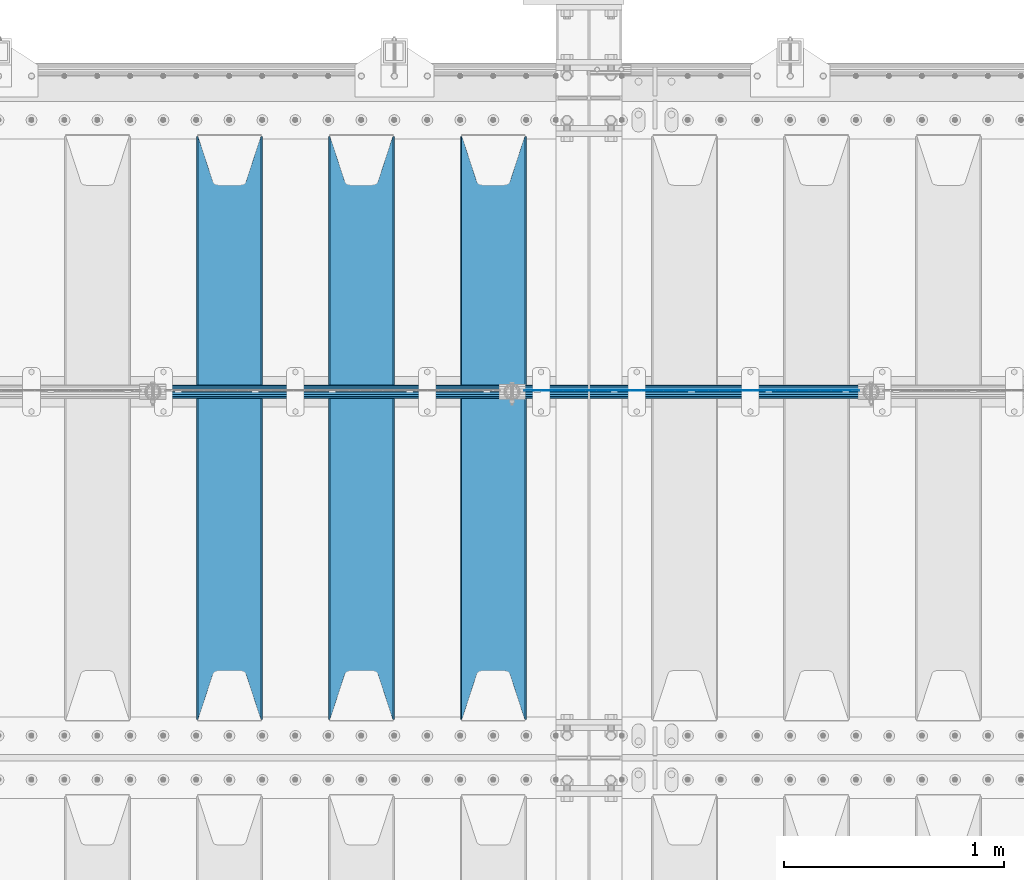
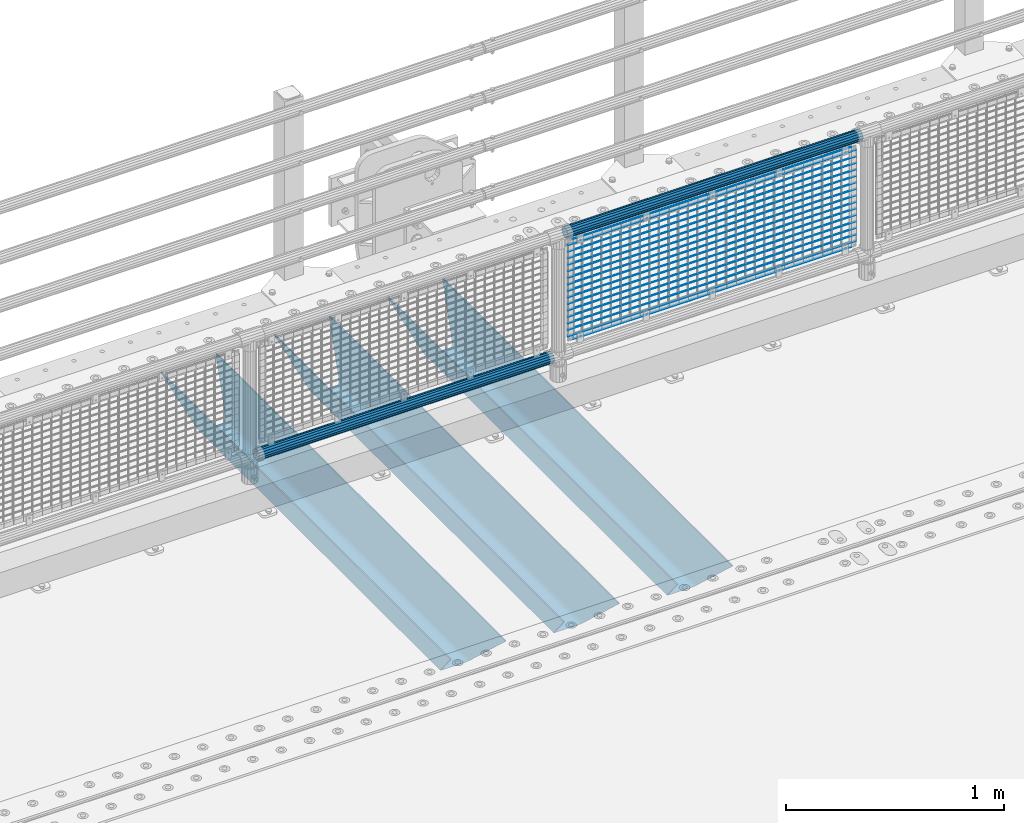
# One storey, part 126 of 242: 22 beams.
"""IFC2X3 building model written with IfcOpenShell, lengths in millimetres."""

import ifcopenshell
import ifcopenshell.guid

model = None  # the IFC model being written
_history = None  # IfcOwnerHistory: only IFC2X3 demands one
_inside = {}  # id of a spatial element -> (the spatial element, [elements in it])
_under = {}  # id of a project, library or spatial element -> (it, [spatial elements below it])
_declared = {}  # id of a project -> (the project, [libraries it declares])
_typed = {}  # id of a type object -> (the type object, [elements of that type])
_made_of = {}  # id of a material, layer set ... -> (it, [elements and type objects made of it])


def new_model(schema):
    """Start an empty IFC model of exactly this schema.

    Asked for "IFC4X3", IfcOpenShell would pick the latest addendum, in which some entities
    have other attributes; the version numbers below select the first issue.
    IFC2X3 requires an IfcOwnerHistory on every rooted entity: one is made here for all.
    """
    global model, _history
    if schema == "IFC4X3":
        model = ifcopenshell.file(schema_version=(4, 3, 0, 0))
    else:
        model = ifcopenshell.file(schema=schema)
    _inside.clear()
    _under.clear()
    _declared.clear()
    _typed.clear()
    _made_of.clear()
    _history = None
    if model.schema == "IFC2X3":
        org = make("IfcOrganization", Name="unknown")
        user = make(
            "IfcPersonAndOrganization",
            ThePerson=make("IfcPerson", FamilyName="unknown"),
            TheOrganization=org,
        )
        app = make(
            "IfcApplication",
            ApplicationDeveloper=org,
            Version="unknown",
            ApplicationFullName="unknown",
            ApplicationIdentifier="unknown",
        )
        _history = make(
            "IfcOwnerHistory",
            OwningUser=user,
            OwningApplication=app,
            ChangeAction="ADDED",
            CreationDate=0,
        )
    return model


def make(cls, **values):
    """One entity of the class cls with the attributes given. An attribute that is None is left unset."""
    return model.create_entity(
        cls, **{name: value for name, value in values.items() if value is not None}
    )


def rooted(cls, **values):
    """An entity with a GlobalId (a new one), such as an element, a storey or a relation."""
    return make(cls, GlobalId=ifcopenshell.guid.new(), OwnerHistory=_history, **values)


def si_unit(unit_type, name, prefix=None):
    """IfcSIUnit, for example si_unit("LENGTHUNIT", "METRE", prefix="MILLI")."""
    return make("IfcSIUnit", UnitType=unit_type, Prefix=prefix, Name=name)


def assignment(units):
    """IfcUnitAssignment: the units of a project."""
    return None if units is None else make("IfcUnitAssignment", Units=units)


def point(xyz):
    """IfcCartesianPoint."""
    return None if xyz is None else make("IfcCartesianPoint", Coordinates=xyz)


def direction(xyz):
    """IfcDirection."""
    return None if xyz is None else make("IfcDirection", DirectionRatios=xyz)


def frame(location, z_axis=None, x_axis=None):
    """IfcAxis2Placement3D, a coordinate frame: its origin and axes. An axis left out is left unset."""
    return make(
        "IfcAxis2Placement3D",
        Location=point(location),
        Axis=direction(z_axis),
        RefDirection=direction(x_axis),
    )


def origin_with_axes():
    """The frame at (0, 0, 0) with the z axis (0, 0, 1) and the x axis (1, 0, 0) written out."""
    return frame((0.0, 0.0, 0.0), z_axis=(0.0, 0.0, 1.0), x_axis=(1.0, 0.0, 0.0))


def place(relative_to, where):
    """IfcLocalPlacement: puts the frame where relative to a parent placement (None: the world)."""
    return make(
        "IfcLocalPlacement", PlacementRelTo=relative_to, RelativePlacement=where
    )


def context(
    kind, dimensions, precision=None, world=None, true_north=None, identifier=None
):
    """IfcGeometricRepresentationContext, for example the 3D "Model" context."""
    return make(
        "IfcGeometricRepresentationContext",
        ContextIdentifier=identifier,
        ContextType=kind,
        CoordinateSpaceDimension=dimensions,
        Precision=precision,
        WorldCoordinateSystem=world,
        TrueNorth=true_north,
    )


def subcontext(parent, identifier, kind, view, scale=None):
    """IfcGeometricRepresentationSubContext, for example "Body" below "Model"."""
    return make(
        "IfcGeometricRepresentationSubContext",
        ContextIdentifier=identifier,
        ContextType=kind,
        ParentContext=parent,
        TargetScale=scale,
        TargetView=view,
    )


def project(units=None, contexts=None):
    """IfcProject with its units and contexts."""
    return rooted(
        "IfcProject",
        Name="project",
        RepresentationContexts=contexts,
        UnitsInContext=assignment(units),
    )


def spatial(cls, under=None, at=None, **own):
    """A site, building, storey or space (cls), placed at a placement, below another one or the project."""
    s = rooted(cls, ObjectPlacement=at, **own)
    if under is not None:
        _under.setdefault(under.id(), (under, []))[1].append(s)
    return s


def faces_of(points, faces, orient=None, outer=None):
    """IfcFace entities. A face is a list of loops; a loop is a list of indices into points, from 0.

    orient and outer hold one flag for each loop. By default every Orientation is true, the
    first loop of a face is its IfcFaceOuterBound and the others are IfcFaceBound.
    """
    made = []
    for i, loops in enumerate(faces):
        bounds = []
        for j, loop in enumerate(loops):
            is_outer = j == 0 if outer is None else outer[i][j]
            bounds.append(
                make(
                    "IfcFaceOuterBound" if is_outer else "IfcFaceBound",
                    Bound=make("IfcPolyLoop", Polygon=[points[k] for k in loop]),
                    Orientation=True if orient is None else orient[i][j],
                )
            )
        made.append(make("IfcFace", Bounds=bounds))
    return made


def faceted_brep(points, faces, orient=None, outer=None, voids=None):
    """IfcFacetedBrep: a solid bounded by flat faces; with voids (closed shells), ...WithVoids."""
    shared = [point(p) for p in points]
    hull = make("IfcClosedShell", CfsFaces=faces_of(shared, faces, orient, outer))
    if voids is None:
        return make("IfcFacetedBrep", Outer=hull)
    return make(
        "IfcFacetedBrepWithVoids",
        Outer=hull,
        Voids=[
            make(cls, CfsFaces=faces_of(shared, fs, o, b)) for cls, fs, o, b in voids
        ],
    )


def shape(context_of_items, identifier, shape_type, items):
    """IfcShapeRepresentation: the items that make up one representation, for example the "Body"."""
    return make(
        "IfcShapeRepresentation",
        ContextOfItems=context_of_items,
        RepresentationIdentifier=identifier,
        RepresentationType=shape_type,
        Items=items,
    )


def material(Name=None, Category=None):
    """IfcMaterial."""
    return make("IfcMaterial", Name=Name, Category=Category)


def made_of(thing, what):
    """Note that an element or type object is made of a material, layer set ...; save() writes the relation."""
    if what is not None:
        _made_of.setdefault(what.id(), (what, []))[1].append(thing)
    return thing


def type_object(cls, material=None, **own):
    """A type object (cls), such as IfcWallType, which elements share."""
    return made_of(rooted(cls, **own), material)


def element(
    cls,
    number,
    at=None,
    inside=None,
    cuts=None,
    type_object=None,
    material=None,
    context=None,
    identifier="Body",
    shape_type=None,
    held_by="IfcProductDefinitionShape",
    body=None,
    shapes=None,
    **own,
):
    """One element of the class cls, such as IfcWall. Its Tag is "e" and its number.

    at: its placement. inside: the storey or other place that contains it. cuts: it is an
    opening in that element (IfcRelVoidsElement). A single representation is given by context,
    identifier, shape_type and body (its items); several are given by shapes. held_by: the class
    of the entity that holds the representations. save() writes the other relations.
    """
    e = rooted(cls, Tag="e%d" % number, ObjectPlacement=at, **own)
    if body is not None:
        shapes = [shape(context, identifier, shape_type, body)]
    if shapes is not None:
        e.Representation = make(held_by, Representations=shapes)
    if inside is not None:
        _inside.setdefault(inside.id(), (inside, []))[1].append(e)
    if cuts is not None:
        rooted(
            "IfcRelVoidsElement", RelatingBuildingElement=cuts, RelatedOpeningElement=e
        )
    if type_object is not None:
        _typed.setdefault(type_object.id(), (type_object, []))[1].append(e)
    return made_of(e, material)


def aggregate(whole, parts):
    """IfcRelAggregates: a whole, such as a stair, and the parts it consists of."""
    return rooted("IfcRelAggregates", RelatingObject=whole, RelatedObjects=parts)


def save(model, path):
    """Write the relations noted so far, then the file.

    IfcRelAggregates (storeys below a building ...), IfcRelContainedInSpatialStructure (elements
    in a storey), IfcRelDefinesByType, IfcRelAssociatesMaterial and IfcRelDeclares: one each for
    every whole, place, type object, material and project.
    """
    for whole, parts in _under.values():
        aggregate(whole, parts)
    for where, things in _inside.values():
        rooted(
            "IfcRelContainedInSpatialStructure",
            RelatedElements=things,
            RelatingStructure=where,
        )
    for kind, things in _typed.values():
        rooted("IfcRelDefinesByType", RelatedObjects=things, RelatingType=kind)
    for what, things in _made_of.values():
        rooted("IfcRelAssociatesMaterial", RelatedObjects=things, RelatingMaterial=what)
    for by, libraries in _declared.values():
        rooted("IfcRelDeclares", RelatingContext=by, RelatedDefinitions=libraries)
    model.write(path)


model = new_model("IFC2X3")

# Units and contexts
model_context = context("Model", 3, precision=1e-05, world=origin_with_axes())
body_context = subcontext(model_context, "Body", "Model", "MODEL_VIEW")
ifc_project = project(units=[si_unit("LENGTHUNIT", "METRE", prefix="MILLI"), si_unit("AREAUNIT", "SQUARE_METRE"), si_unit("VOLUMEUNIT", "CUBIC_METRE"), si_unit("MASSUNIT", "GRAM", prefix="KILO"), si_unit("TIMEUNIT", "SECOND"), si_unit("PLANEANGLEUNIT", "RADIAN"), si_unit("SOLIDANGLEUNIT", "STERADIAN"), si_unit("THERMODYNAMICTEMPERATUREUNIT", "DEGREE_CELSIUS"), si_unit("LUMINOUSINTENSITYUNIT", "LUMEN")], contexts=[model_context])

# Site, building, storey
site_placement = place(None, origin_with_axes())
site = spatial("IfcSite", under=ifc_project, at=site_placement, CompositionType="ELEMENT")
building_placement = place(site_placement, origin_with_axes())
building = spatial("IfcBuilding", under=site, at=building_placement, Name="Standard", CompositionType="ELEMENT")
storey_placement = place(building_placement, origin_with_axes())
storey = spatial("IfcBuildingStorey", under=building, at=storey_placement, Name="Undefined", CompositionType="ELEMENT", Elevation=0.0)

# Beams
ifc_material_1 = material(Name="Misc_Undefined")
beam_type_1 = type_object("IfcBeamType", Name="D3", PredefinedType="NOTDEFINED")
for number, where, z_axis, x_axis in (
    (1, (-28710.0, -19329.5, 851.596999999999), (0.0, 0.0, 1.0), (1.0, 0.0, 0.0)),
    (2, (-28710.0, -19329.5, 669.452), (0.0, 0.0, 1.0), (1.0, 0.0, 0.0)),
    (3, (-28710.0, -19329.5, 523.736), (0.0, 0.0, 1.0), (1.0, 0.0, 0.0)),
    (4, (-28710.0, -19329.5, 487.307), (0.0, 0.0, 1.0), (1.0, 0.0, 0.0)),
    (5, (-28710.0, -19329.5, 705.881), (0.0, 0.0, 1.0), (1.0, 0.0, 0.0)),
    (6, (-28710.0, -19329.5, 596.594), (0.0, 0.0, 1.0), (1.0, 0.0, 0.0)),
    (7, (-28710.0, -19329.5, 450.878), (0.0, 0.0, 1.0), (1.0, 0.0, 0.0)),
    (8, (-28710.0, -19329.5, 815.167999999999), (0.0, 0.0, 1.0), (1.0, 0.0, 0.0)),
    (9, (-28710.0, -19329.5, 888.025999999999), (0.0, 0.0, 1.0), (1.0, 0.0, 0.0)),
    (10, (-28710.0, -19329.5, 778.738999999999), (0.0, 0.0, 1.0), (1.0, 0.0, 0.0)),
    (11, (-28710.0, -19329.5, 742.309999999999), (0.0, 0.0, 1.0), (1.0, 0.0, 0.0)),
    (12, (-28710.0, -19329.5, 633.023), (0.0, 0.0, 1.0), (1.0, 0.0, 0.0)),
    (13, (-28710.0, -19329.5, 560.165), (0.0, 0.0, 1.0), (1.0, 0.0, 0.0)),
    (14, (-28710.0, -19329.5, 414.449), (0.0, 0.0, 1.0), (1.0, 0.0, 0.0)),
):
    element("IfcBeam", number, at=place(storey_placement, frame(where, z_axis=z_axis, x_axis=x_axis)), inside=storey, type_object=beam_type_1, material=ifc_material_1, ObjectType="D3", context=body_context, shape_type="Brep", body=[
        faceted_brep([(0.0, -1.50000000000364, 0.0), (-3.63797880709171e-12, -0.750000000003638, -1.29903810567669), (1523.0, -0.75, -1.29903810567669), (1523.0, -1.5, 0.0), (0.0, 0.749999999996362, -1.29903810567669), (1523.0, 0.75, -1.29903810567669), (-3.63797880709171e-12, 1.49999999999636, 0.0), (1523.0, 1.5, 0.0), (0.0, 0.749999999996362, 1.29903810567669), (1523.0, 0.75, 1.29903810567669), (-3.63797880709171e-12, -0.750000000003638, 1.29903810567669), (1523.0, -0.75, 1.29903810567669)], [[[0, 1, 2, 3]], [[1, 4, 5, 2]], [[4, 6, 7, 5]], [[6, 8, 9, 7]], [[8, 10, 11, 9]], [[10, 0, 3, 11]], [[5, 7, 9, 11, 3, 2]], [[10, 8, 6, 4, 1, 0]]]),
    ])
beam_1_placement = place(storey_placement, frame((-28685.0, -19329.5, 353.02), z_axis=(0.0, 0.0, 1.0), x_axis=(1.0, 0.0, 0.0)))
element("IfcBeam", 15, at=beam_1_placement, inside=storey, type_object=beam_type_1, material=ifc_material_1, ObjectType="D3", context=body_context, shape_type="Brep", body=[
    faceted_brep([(0.0, -1.50000000000364, 0.0), (-3.63797880709171e-12, -0.750000000003638, -1.29903810567669), (1473.0, -0.75, -1.29903810567669), (1473.0, -1.5, 0.0), (0.0, 0.749999999996362, -1.29903810567669), (1473.0, 0.75, -1.29903810567663), (-3.63797880709171e-12, 1.49999999999636, 0.0), (1473.0, 1.5, 0.0), (0.0, 0.749999999996362, 1.29903810567669), (1473.0, 0.75, 1.29903810567669), (-3.63797880709171e-12, -0.750000000003638, 1.29903810567669), (1473.0, -0.75, 1.29903810567669)], [[[0, 1, 2, 3]], [[1, 4, 5, 2]], [[4, 6, 7, 5]], [[6, 8, 9, 7]], [[8, 10, 11, 9]], [[10, 0, 3, 11]], [[5, 7, 9, 11, 3, 2]], [[10, 8, 6, 4, 1, 0]]]),
])
beam_2_placement = place(storey_placement, frame((-28710.0, -19329.5, 378.02), z_axis=(0.0, 0.0, 1.0), x_axis=(1.0, 0.0, 0.0)))
element("IfcBeam", 16, at=beam_2_placement, inside=storey, type_object=beam_type_1, material=ifc_material_1, ObjectType="D3", context=body_context, shape_type="Brep", body=[
    faceted_brep([(0.0, -1.50000000000364, 0.0), (-3.63797880709171e-12, -0.750000000003638, -1.29903810567669), (1523.0, -0.75, -1.29903810567669), (1523.0, -1.5, 0.0), (0.0, 0.749999999996362, -1.29903810567669), (1523.0, 0.75, -1.29903810567669), (-3.63797880709171e-12, 1.49999999999636, 0.0), (1523.0, 1.5, 0.0), (0.0, 0.749999999996362, 1.29903810567669), (1523.0, 0.75, 1.29903810567669), (-3.63797880709171e-12, -0.750000000003638, 1.29903810567669), (1523.0, -0.75, 1.29903810567669)], [[[0, 1, 2, 3]], [[1, 4, 5, 2]], [[4, 6, 7, 5]], [[6, 8, 9, 7]], [[8, 10, 11, 9]], [[10, 0, 3, 11]], [[5, 7, 9, 11, 3, 2]], [[10, 8, 6, 4, 1, 0]]]),
])
beam_3_placement = place(storey_placement, frame((-28685.0, -19329.5, 913.02), z_axis=(0.0, 0.0, 1.0), x_axis=(1.0, 0.0, 0.0)))
element("IfcBeam", 17, at=beam_3_placement, inside=storey, type_object=beam_type_1, material=ifc_material_1, ObjectType="D3", context=body_context, shape_type="Brep", body=[
    faceted_brep([(0.0, -1.50000000000364, 0.0), (-3.63797880709171e-12, -0.750000000003638, -1.29903810567669), (1473.0, -0.75, -1.29903810567669), (1473.0, -1.5, 0.0), (0.0, 0.749999999996362, -1.29903810567669), (1473.0, 0.75, -1.29903810567663), (-3.63797880709171e-12, 1.49999999999636, 0.0), (1473.0, 1.5, 0.0), (0.0, 0.749999999996362, 1.29903810567669), (1473.0, 0.75, 1.29903810567669), (-3.63797880709171e-12, -0.750000000003638, 1.29903810567669), (1473.0, -0.75, 1.29903810567669)], [[[0, 1, 2, 3]], [[1, 4, 5, 2]], [[4, 6, 7, 5]], [[6, 8, 9, 7]], [[8, 10, 11, 9]], [[10, 0, 3, 11]], [[5, 7, 9, 11, 3, 2]], [[10, 8, 6, 4, 1, 0]]]),
])
ifc_material_2 = material()
beam_type_2 = type_object("IfcBeamType", PredefinedType="NOTDEFINED")
beam_4_placement = place(storey_placement, frame((-28730.15, -19335.5, 969.849999999999), z_axis=(0.0, 0.0, 1.0), x_axis=(1.0, 0.0, 0.0)))
element("IfcBeam", 18, at=beam_4_placement, inside=storey, type_object=beam_type_2, material=ifc_material_2, context=body_context, shape_type="Brep", body=[
    faceted_brep([(0.0, -25.3499999999985, 0.0), (0.0, -23.4203461491597, 9.70102501045403), (1563.0, -23.4203461491597, 9.70102501045506), (1563.0, -25.3499999999985, 0.0), (0.0, -17.9251569030785, 17.9251569030785), (1563.0, -17.9251569030785, 17.925156903079), (0.0, -9.70102501045403, 23.4203461491597), (1563.0, -9.70102501045403, 23.4203461491611), (0.0, 0.0, 25.3499999999985), (1563.0, 0.0, 25.35), (0.0, 9.70102501045403, 23.4203461491597), (1563.0, 9.70102501045403, 23.4203461491611), (0.0, 17.9251569030785, 17.9251569030785), (1563.0, 17.9251569030785, 17.925156903079), (0.0, 23.4203461491597, 9.70102501045403), (1563.0, 23.4203461491597, 9.70102501045506), (0.0, 25.3499999999985, 0.0), (1563.0, 25.3499999999985, 0.0), (0.0, 23.4203461491597, -9.70102501045403), (1563.0, 23.4203461491597, -9.70102501045506), (0.0, 17.9251569030785, -17.9251569030785), (1563.0, 17.9251569030785, -17.925156903079), (0.0, 9.70102501045403, -23.4203461491597), (1563.0, 9.70102501045403, -23.4203461491611), (0.0, 0.0, -25.3499999999985), (1563.0, 0.0, -25.35), (0.0, -9.70102501045403, -23.4203461491597), (1563.0, -9.70102501045403, -23.4203461491611), (0.0, -17.9251569030785, -17.9251569030785), (1563.0, -17.9251569030785, -17.925156903079), (0.0, -23.4203461491597, -9.70102501045403), (1563.0, -23.4203461491597, -9.70102501045506), (0.0, -30.1500000000015, 0.0), (0.0, -27.8549679052157, -11.5379054858058), (1563.0, -27.8549679052157, -11.5379054858075), (1563.0, -30.1500000000015, 0.0), (0.0, -21.3192694527752, -21.3192694527752), (1563.0, -21.3192694527752, -21.3192694527744), (0.0, -11.5379054858058, -27.8549679052157), (1563.0, -11.5379054858058, -27.8549679052153), (0.0, 0.0, -30.1500000000015), (1563.0, 0.0, -30.15), (0.0, 11.5379054858058, -27.8549679052157), (1563.0, 11.5379054858058, -27.8549679052153), (0.0, 21.3192694527752, -21.3192694527752), (1563.0, 21.3192694527752, -21.3192694527744), (0.0, 27.8549679052157, -11.5379054858058), (1563.0, 27.8549679052157, -11.5379054858074), (0.0, 30.1500000000015, 0.0), (1563.0, 30.1500000000015, 0.0), (0.0, 27.8549679052157, 11.5379054858058), (1563.0, 27.8549679052157, 11.5379054858074), (0.0, 21.3192694527752, 21.3192694527752), (1563.0, 21.3192694527752, 21.3192694527744), (0.0, 11.5379054858058, 27.8549679052157), (1563.0, 11.5379054858058, 27.8549679052153), (0.0, 0.0, 30.1500000000015), (1563.0, 0.0, 30.15), (0.0, -11.5379054858058, 27.8549679052157), (1563.0, -11.5379054858058, 27.8549679052153), (0.0, -21.3192694527752, 21.3192694527752), (1563.0, -21.3192694527752, 21.3192694527744), (0.0, -27.8549679052157, 11.5379054858058), (1563.0, -27.8549679052157, 11.5379054858074)], [[[0, 1, 2, 3]], [[1, 4, 5, 2]], [[4, 6, 7, 5]], [[6, 8, 9, 7]], [[8, 10, 11, 9]], [[10, 12, 13, 11]], [[12, 14, 15, 13]], [[14, 16, 17, 15]], [[16, 18, 19, 17]], [[18, 20, 21, 19]], [[20, 22, 23, 21]], [[22, 24, 25, 23]], [[24, 26, 27, 25]], [[26, 28, 29, 27]], [[28, 30, 31, 29]], [[30, 0, 3, 31]], [[32, 33, 34, 35]], [[33, 36, 37, 34]], [[36, 38, 39, 37]], [[38, 40, 41, 39]], [[40, 42, 43, 41]], [[42, 44, 45, 43]], [[44, 46, 47, 45]], [[46, 48, 49, 47]], [[48, 50, 51, 49]], [[50, 52, 53, 51]], [[52, 54, 55, 53]], [[54, 56, 57, 55]], [[56, 58, 59, 57]], [[58, 60, 61, 59]], [[60, 62, 63, 61]], [[62, 32, 35, 63]], [[37, 39, 41, 43, 45, 47, 49, 51, 53, 55, 57, 59, 61, 63, 35, 34], [5, 7, 9, 11, 13, 15, 17, 19, 21, 23, 25, 27, 29, 31, 3, 2]], [[62, 60, 58, 56, 54, 52, 50, 48, 46, 44, 42, 40, 38, 36, 33, 32], [30, 28, 26, 24, 22, 20, 18, 16, 14, 12, 10, 8, 6, 4, 1, 0]]]),
])
beam_5_placement = place(storey_placement, frame((-30363.15, -19335.5, 298.170000000001), z_axis=(0.0, 0.0, 1.0), x_axis=(1.0, 0.0, 0.0)))
element("IfcBeam", 19, at=beam_5_placement, inside=storey, type_object=beam_type_2, material=ifc_material_2, context=body_context, shape_type="Brep", body=[
    faceted_brep([(0.0, -25.3499999999985, 0.0), (0.0, -23.4203461491597, 9.70102501045403), (1563.0, -23.4203461491597, 9.70102501045506), (1563.0, -25.3499999999985, 0.0), (0.0, -17.9251569030785, 17.9251569030785), (1563.0, -17.9251569030785, 17.925156903079), (0.0, -9.70102501045403, 23.4203461491597), (1563.0, -9.70102501045403, 23.4203461491611), (0.0, 0.0, 25.3499999999985), (1563.0, 0.0, 25.35), (0.0, 9.70102501045403, 23.4203461491597), (1563.0, 9.70102501045403, 23.4203461491611), (0.0, 17.9251569030785, 17.9251569030785), (1563.0, 17.9251569030785, 17.925156903079), (0.0, 23.4203461491597, 9.70102501045403), (1563.0, 23.4203461491597, 9.70102501045506), (0.0, 25.3499999999985, 0.0), (1563.0, 25.3499999999985, 0.0), (0.0, 23.4203461491597, -9.70102501045403), (1563.0, 23.4203461491597, -9.70102501045506), (0.0, 17.9251569030785, -17.9251569030785), (1563.0, 17.9251569030785, -17.925156903079), (0.0, 9.70102501045403, -23.4203461491597), (1563.0, 9.70102501045403, -23.4203461491611), (0.0, 0.0, -25.3499999999985), (1563.0, 0.0, -25.35), (0.0, -9.70102501045403, -23.4203461491597), (1563.0, -9.70102501045403, -23.4203461491611), (0.0, -17.9251569030785, -17.9251569030785), (1563.0, -17.9251569030785, -17.925156903079), (0.0, -23.4203461491597, -9.70102501045403), (1563.0, -23.4203461491597, -9.70102501045506), (0.0, -30.1500000000015, 0.0), (0.0, -27.8549679052157, -11.5379054858058), (1563.0, -27.8549679052157, -11.5379054858075), (1563.0, -30.1500000000015, 0.0), (0.0, -21.3192694527752, -21.3192694527752), (1563.0, -21.3192694527752, -21.3192694527744), (0.0, -11.5379054858058, -27.8549679052157), (1563.0, -11.5379054858058, -27.8549679052153), (0.0, 0.0, -30.1500000000015), (1563.0, 0.0, -30.15), (0.0, 11.5379054858058, -27.8549679052157), (1563.0, 11.5379054858058, -27.8549679052153), (0.0, 21.3192694527752, -21.3192694527752), (1563.0, 21.3192694527752, -21.3192694527744), (0.0, 27.8549679052157, -11.5379054858058), (1563.0, 27.8549679052157, -11.5379054858074), (0.0, 30.1500000000015, 0.0), (1563.0, 30.1500000000015, 0.0), (0.0, 27.8549679052157, 11.5379054858058), (1563.0, 27.8549679052157, 11.5379054858074), (0.0, 21.3192694527752, 21.3192694527752), (1563.0, 21.3192694527752, 21.3192694527744), (0.0, 11.5379054858058, 27.8549679052157), (1563.0, 11.5379054858058, 27.8549679052153), (0.0, 0.0, 30.1500000000015), (1563.0, 0.0, 30.15), (0.0, -11.5379054858058, 27.8549679052157), (1563.0, -11.5379054858058, 27.8549679052153), (0.0, -21.3192694527752, 21.3192694527752), (1563.0, -21.3192694527752, 21.3192694527744), (0.0, -27.8549679052157, 11.5379054858058), (1563.0, -27.8549679052157, 11.5379054858074)], [[[0, 1, 2, 3]], [[1, 4, 5, 2]], [[4, 6, 7, 5]], [[6, 8, 9, 7]], [[8, 10, 11, 9]], [[10, 12, 13, 11]], [[12, 14, 15, 13]], [[14, 16, 17, 15]], [[16, 18, 19, 17]], [[18, 20, 21, 19]], [[20, 22, 23, 21]], [[22, 24, 25, 23]], [[24, 26, 27, 25]], [[26, 28, 29, 27]], [[28, 30, 31, 29]], [[30, 0, 3, 31]], [[32, 33, 34, 35]], [[33, 36, 37, 34]], [[36, 38, 39, 37]], [[38, 40, 41, 39]], [[40, 42, 43, 41]], [[42, 44, 45, 43]], [[44, 46, 47, 45]], [[46, 48, 49, 47]], [[48, 50, 51, 49]], [[50, 52, 53, 51]], [[52, 54, 55, 53]], [[54, 56, 57, 55]], [[56, 58, 59, 57]], [[58, 60, 61, 59]], [[60, 62, 63, 61]], [[62, 32, 35, 63]], [[37, 39, 41, 43, 45, 47, 49, 51, 53, 55, 57, 59, 61, 63, 35, 34], [5, 7, 9, 11, 13, 15, 17, 19, 21, 23, 25, 27, 29, 31, 3, 2]], [[62, 60, 58, 56, 54, 52, 50, 48, 46, 44, 42, 40, 38, 36, 33, 32], [30, 28, 26, 24, 22, 20, 18, 16, 14, 12, 10, 8, 6, 4, 1, 0]]]),
])
ifc_material_3 = material(Name="STEEL/S355N")
beam_type_3 = type_object("IfcBeamType", PredefinedType="NOTDEFINED")
beam_6_placement = place(storey_placement, frame((-28850.0, -20825.0, -115.0), z_axis=(0.0, 0.0, 1.0), x_axis=(0.0, 1.0, 0.0)))
element("IfcBeam", 20, at=beam_6_placement, inside=storey, type_object=beam_type_3, material=ifc_material_3, context=body_context, shape_type="Brep", body=[
    faceted_brep([(0.0, 150.0, 115.0), (0.0, 143.689999999999, 115.0), (2650.00000000297, 143.689999999999, 115.0), (2650.00000000297, 150.0, 115.0), (2650.00000000297, 142.059565218402, 110.000000003099), (2650.00000000297, 148.369565218403, 110.000000003099), (2441.90079219209, -80.1103600731112, -98.0992078077845), (2437.7588105432, -77.5672621345584, -102.241189456673), (2434.06523489747, -74.4080125315522, -105.934765102404), (2430.91086095089, -70.710272125576, -109.089139048974), (2428.37322971128, -66.5649389910068, -111.626770288588), (2426.51472138055, -62.0739139532889, -113.485278619323), (2425.38102192092, -57.3475956567672, -114.618978078955), (2424.99999999987, -52.5021667386536, -115.0), (2424.99999999987, 52.5021667386536, -115.0), (2425.38102192092, 57.3475956567672, -114.618978078955), (2426.51472138055, 62.0739139532889, -113.485278619323), (2428.37322971128, 66.5649389910068, -111.626770288588), (2430.91086095089, 70.710272125576, -109.089139048974), (2434.06523489747, 74.4080125315522, -105.934765102404), (2437.7588105432, 77.5672621345584, -102.241189456673), (2441.90079219209, 80.1103600731112, -98.0992078077846), (2446.38936140511, 81.9747917625791, -93.6106385947584), (2448.2494850041, 76.2713538057251, -91.7505149957729), (2444.62967112262, 74.76777986261, -95.3703288772456), (2441.28936334126, 72.7168944282894, -98.710636658607), (2438.31067330438, 70.1691124903846, -101.689326695487), (2435.76682334747, 67.1870637758839, -104.233176652398), (2433.72034654133, 63.8440531834895, -106.279653458539), (2432.22154950042, 60.222258798236, -107.778450499454), (2431.30727574265, 56.4107117849089, -108.692724257221), (2430.99999999987, 52.5031078186876, -109.0), (2430.99999999987, -52.5031078186876, -109.0), (2431.30727574265, -56.4107117849089, -108.692724257221), (2432.22154950042, -60.222258798236, -107.778450499454), (2433.72034654133, -63.8440531834895, -106.279653458539), (2435.76682334747, -67.1870637758839, -104.233176652398), (2438.31067330438, -70.1691124903846, -101.689326695487), (2441.28936334126, -72.7168944282894, -98.7106366586071), (2444.62967112262, -74.76777986261, -95.3703288772457), (2448.2494850041, -76.2713538057251, -91.7505149957729), (2650.00000000297, -142.059565218402, 110.000000003099), (2650.00000000297, -148.369565218403, 110.000000003099), (2446.38936140511, -81.9747917625791, -93.6106385947584), (2650.00000000297, -143.689999999999, 115.0), (2650.00000000297, -150.0, 115.0), (0.0, -143.689999999999, 115.0), (0.0, -150.0, 115.0), (0.0, -148.369565218261, 110.000000002669), (203.610638597427, -81.9747917625791, -93.6106385947584), (208.099207810454, -80.1103600731112, -98.0992078077845), (212.241189459342, -77.5672621345584, -102.241189456673), (215.934765105074, -74.4080125315522, -105.934765102404), (219.089139051644, -70.710272125576, -109.089139048974), (221.626770291256, -66.5649389910068, -111.626770288588), (223.485278621993, -62.0739139532889, -113.485278619323), (224.618978081624, -57.3475956567672, -114.618978078955), (225.00000000267, -52.5021667386536, -115.0), (225.00000000267, 52.5021667386536, -115.0), (224.618978081624, 57.3475956567672, -114.618978078955), (223.485278621993, 62.0739139532889, -113.485278619323), (221.626770291256, 66.5649389910068, -111.626770288588), (219.089139051644, 70.710272125576, -109.089139048974), (215.934765105074, 74.4080125315522, -105.934765102404), (212.241189459342, 77.5672621345584, -102.241189456673), (208.099207810454, 80.1103600731112, -98.0992078077846), (203.610638597427, 81.9747917625791, -93.6106385947584), (0.0, 148.369565218261, 110.000000002669), (0.0, 142.05956521826, 110.000000002669), (201.750514998443, 76.2713538057251, -91.7505149957729), (205.370328879915, 74.76777986261, -95.3703288772456), (208.710636661275, 72.7168944282894, -98.710636658607), (211.689326698157, 70.1691124903846, -101.689326695487), (214.233176655067, 67.1870637758839, -104.233176652398), (216.279653461206, 63.8440531834895, -106.279653458539), (217.778450502123, 60.222258798236, -107.778450499454), (218.69272425989, 56.4107117849089, -108.692724257221), (219.00000000267, 52.5031078186876, -109.0), (219.00000000267, -52.5031078186876, -109.0), (218.69272425989, -56.4107117849089, -108.692724257221), (217.778450502123, -60.222258798236, -107.778450499454), (216.279653461206, -63.8440531834895, -106.279653458539), (214.233176655067, -67.1870637758839, -104.233176652398), (211.689326698157, -70.1691124903846, -101.689326695487), (208.710636661275, -72.7168944282894, -98.7106366586071), (205.370328879915, -74.76777986261, -95.3703288772457), (201.750514998443, -76.2713538057251, -91.7505149957729), (0.0, -142.05956521826, 110.000000002669)], [[[0, 1, 2, 3]], [[3, 2, 4, 5]], [[6, 7, 8, 9, 10, 11, 12, 13, 14, 15, 16, 17, 18, 19, 20, 21, 22, 5, 4, 23, 24, 25, 26, 27, 28, 29, 30, 31, 32, 33, 34, 35, 36, 37, 38, 39, 40, 41, 42, 43]], [[44, 45, 42, 41]], [[46, 47, 45, 44]], [[43, 42, 45, 47, 48, 49]], [[6, 43, 49, 50]], [[7, 6, 50, 51]], [[8, 7, 51, 52]], [[9, 8, 52, 53]], [[10, 9, 53, 54]], [[11, 10, 54, 55]], [[12, 11, 55, 56]], [[13, 12, 56, 57]], [[14, 13, 57, 58]], [[15, 14, 58, 59]], [[16, 15, 59, 60]], [[17, 16, 60, 61]], [[18, 17, 61, 62]], [[19, 18, 62, 63]], [[20, 19, 63, 64]], [[21, 20, 64, 65]], [[22, 21, 65, 66]], [[0, 3, 5, 22, 66, 67]], [[1, 0, 67, 68]], [[23, 4, 2, 1, 68, 69]], [[24, 23, 69, 70]], [[25, 24, 70, 71]], [[26, 25, 71, 72]], [[27, 26, 72, 73]], [[28, 27, 73, 74]], [[29, 28, 74, 75]], [[30, 29, 75, 76]], [[31, 30, 76, 77]], [[32, 31, 77, 78]], [[33, 32, 78, 79]], [[34, 33, 79, 80]], [[35, 34, 80, 81]], [[36, 35, 81, 82]], [[37, 36, 82, 83]], [[38, 37, 83, 84]], [[39, 38, 84, 85]], [[40, 39, 85, 86]], [[46, 44, 41, 40, 86, 87]], [[47, 46, 87, 48]], [[86, 85, 84, 83, 82, 81, 80, 79, 78, 77, 76, 75, 74, 73, 72, 71, 70, 69, 68, 67, 66, 65, 64, 63, 62, 61, 60, 59, 58, 57, 56, 55, 54, 53, 52, 51, 50, 49, 48, 87]]]),
])
beam_7_placement = place(storey_placement, frame((-29450.0, -20825.0, -115.0), z_axis=(0.0, 0.0, 1.0), x_axis=(0.0, 1.0, 0.0)))
element("IfcBeam", 21, at=beam_7_placement, inside=storey, type_object=beam_type_3, material=ifc_material_3, context=body_context, shape_type="Brep", body=[
    faceted_brep([(0.0, 150.0, 115.0), (0.0, 143.689999999999, 115.0), (2650.00000000297, 143.689999999999, 115.0), (2650.00000000297, 150.0, 115.0), (2650.00000000297, 142.059565218402, 110.000000003099), (2650.00000000297, 148.369565218403, 110.000000003099), (2441.90079219209, -80.1103600731112, -98.0992078077845), (2437.7588105432, -77.5672621345584, -102.241189456673), (2434.06523489747, -74.4080125315522, -105.934765102404), (2430.91086095089, -70.710272125576, -109.089139048974), (2428.37322971128, -66.5649389910068, -111.626770288588), (2426.51472138055, -62.0739139532889, -113.485278619323), (2425.38102192092, -57.3475956567672, -114.618978078955), (2424.99999999987, -52.5021667386536, -115.0), (2424.99999999987, 52.5021667386536, -115.0), (2425.38102192092, 57.3475956567672, -114.618978078955), (2426.51472138055, 62.0739139532889, -113.485278619323), (2428.37322971128, 66.5649389910068, -111.626770288588), (2430.91086095089, 70.710272125576, -109.089139048974), (2434.06523489747, 74.4080125315522, -105.934765102404), (2437.7588105432, 77.5672621345584, -102.241189456673), (2441.90079219209, 80.1103600731112, -98.0992078077846), (2446.38936140511, 81.9747917625791, -93.6106385947584), (2448.2494850041, 76.2713538057251, -91.7505149957729), (2444.62967112262, 74.76777986261, -95.3703288772456), (2441.28936334126, 72.7168944282894, -98.710636658607), (2438.31067330438, 70.1691124903846, -101.689326695487), (2435.76682334747, 67.1870637758839, -104.233176652398), (2433.72034654133, 63.8440531834895, -106.279653458539), (2432.22154950042, 60.222258798236, -107.778450499454), (2431.30727574265, 56.4107117849089, -108.692724257221), (2430.99999999987, 52.5031078186876, -109.0), (2430.99999999987, -52.5031078186876, -109.0), (2431.30727574265, -56.4107117849089, -108.692724257221), (2432.22154950042, -60.222258798236, -107.778450499454), (2433.72034654133, -63.8440531834895, -106.279653458539), (2435.76682334747, -67.1870637758839, -104.233176652398), (2438.31067330438, -70.1691124903846, -101.689326695487), (2441.28936334126, -72.7168944282894, -98.7106366586071), (2444.62967112262, -74.76777986261, -95.3703288772457), (2448.2494850041, -76.2713538057251, -91.7505149957729), (2650.00000000297, -142.059565218402, 110.000000003099), (2650.00000000297, -148.369565218403, 110.000000003099), (2446.38936140511, -81.9747917625791, -93.6106385947584), (2650.00000000297, -143.689999999999, 115.0), (2650.00000000297, -150.0, 115.0), (0.0, -143.689999999999, 115.0), (0.0, -150.0, 115.0), (0.0, -148.369565218261, 110.000000002669), (203.610638597427, -81.9747917625791, -93.6106385947584), (208.099207810454, -80.1103600731112, -98.0992078077845), (212.241189459342, -77.5672621345584, -102.241189456673), (215.934765105074, -74.4080125315522, -105.934765102404), (219.089139051644, -70.710272125576, -109.089139048974), (221.626770291256, -66.5649389910068, -111.626770288588), (223.485278621993, -62.0739139532889, -113.485278619323), (224.618978081624, -57.3475956567672, -114.618978078955), (225.00000000267, -52.5021667386536, -115.0), (225.00000000267, 52.5021667386536, -115.0), (224.618978081624, 57.3475956567672, -114.618978078955), (223.485278621993, 62.0739139532889, -113.485278619323), (221.626770291256, 66.5649389910068, -111.626770288588), (219.089139051644, 70.710272125576, -109.089139048974), (215.934765105074, 74.4080125315522, -105.934765102404), (212.241189459342, 77.5672621345584, -102.241189456673), (208.099207810454, 80.1103600731112, -98.0992078077846), (203.610638597427, 81.9747917625791, -93.6106385947584), (0.0, 148.369565218261, 110.000000002669), (0.0, 142.05956521826, 110.000000002669), (201.750514998443, 76.2713538057251, -91.7505149957729), (205.370328879915, 74.76777986261, -95.3703288772456), (208.710636661275, 72.7168944282894, -98.710636658607), (211.689326698157, 70.1691124903846, -101.689326695487), (214.233176655067, 67.1870637758839, -104.233176652398), (216.279653461206, 63.8440531834895, -106.279653458539), (217.778450502123, 60.222258798236, -107.778450499454), (218.69272425989, 56.4107117849089, -108.692724257221), (219.00000000267, 52.5031078186876, -109.0), (219.00000000267, -52.5031078186876, -109.0), (218.69272425989, -56.4107117849089, -108.692724257221), (217.778450502123, -60.222258798236, -107.778450499454), (216.279653461206, -63.8440531834895, -106.279653458539), (214.233176655067, -67.1870637758839, -104.233176652398), (211.689326698157, -70.1691124903846, -101.689326695487), (208.710636661275, -72.7168944282894, -98.7106366586071), (205.370328879915, -74.76777986261, -95.3703288772457), (201.750514998443, -76.2713538057251, -91.7505149957729), (0.0, -142.05956521826, 110.000000002669)], [[[0, 1, 2, 3]], [[3, 2, 4, 5]], [[6, 7, 8, 9, 10, 11, 12, 13, 14, 15, 16, 17, 18, 19, 20, 21, 22, 5, 4, 23, 24, 25, 26, 27, 28, 29, 30, 31, 32, 33, 34, 35, 36, 37, 38, 39, 40, 41, 42, 43]], [[44, 45, 42, 41]], [[46, 47, 45, 44]], [[43, 42, 45, 47, 48, 49]], [[6, 43, 49, 50]], [[7, 6, 50, 51]], [[8, 7, 51, 52]], [[9, 8, 52, 53]], [[10, 9, 53, 54]], [[11, 10, 54, 55]], [[12, 11, 55, 56]], [[13, 12, 56, 57]], [[14, 13, 57, 58]], [[15, 14, 58, 59]], [[16, 15, 59, 60]], [[17, 16, 60, 61]], [[18, 17, 61, 62]], [[19, 18, 62, 63]], [[20, 19, 63, 64]], [[21, 20, 64, 65]], [[22, 21, 65, 66]], [[0, 3, 5, 22, 66, 67]], [[1, 0, 67, 68]], [[23, 4, 2, 1, 68, 69]], [[24, 23, 69, 70]], [[25, 24, 70, 71]], [[26, 25, 71, 72]], [[27, 26, 72, 73]], [[28, 27, 73, 74]], [[29, 28, 74, 75]], [[30, 29, 75, 76]], [[31, 30, 76, 77]], [[32, 31, 77, 78]], [[33, 32, 78, 79]], [[34, 33, 79, 80]], [[35, 34, 80, 81]], [[36, 35, 81, 82]], [[37, 36, 82, 83]], [[38, 37, 83, 84]], [[39, 38, 84, 85]], [[40, 39, 85, 86]], [[46, 44, 41, 40, 86, 87]], [[47, 46, 87, 48]], [[86, 85, 84, 83, 82, 81, 80, 79, 78, 77, 76, 75, 74, 73, 72, 71, 70, 69, 68, 67, 66, 65, 64, 63, 62, 61, 60, 59, 58, 57, 56, 55, 54, 53, 52, 51, 50, 49, 48, 87]]]),
])
beam_8_placement = place(storey_placement, frame((-30050.0, -20825.0, -115.0), z_axis=(0.0, 0.0, 1.0), x_axis=(0.0, 1.0, 0.0)))
element("IfcBeam", 22, at=beam_8_placement, inside=storey, type_object=beam_type_3, material=ifc_material_3, context=body_context, shape_type="Brep", body=[
    faceted_brep([(0.0, 150.0, 115.0), (0.0, 143.689999999999, 115.0), (2650.00000000297, 143.689999999999, 115.0), (2650.00000000297, 150.0, 115.0), (2650.00000000297, 142.059565218402, 110.000000003099), (2650.00000000297, 148.369565218403, 110.000000003099), (2441.90079219209, -80.1103600731112, -98.0992078077845), (2437.7588105432, -77.5672621345584, -102.241189456673), (2434.06523489747, -74.4080125315522, -105.934765102404), (2430.91086095089, -70.710272125576, -109.089139048974), (2428.37322971128, -66.5649389910068, -111.626770288588), (2426.51472138055, -62.0739139532889, -113.485278619323), (2425.38102192092, -57.3475956567672, -114.618978078955), (2424.99999999987, -52.5021667386536, -115.0), (2424.99999999987, 52.5021667386536, -115.0), (2425.38102192092, 57.3475956567672, -114.618978078955), (2426.51472138055, 62.0739139532889, -113.485278619323), (2428.37322971128, 66.5649389910068, -111.626770288588), (2430.91086095089, 70.710272125576, -109.089139048974), (2434.06523489747, 74.4080125315522, -105.934765102404), (2437.7588105432, 77.5672621345584, -102.241189456673), (2441.90079219209, 80.1103600731112, -98.0992078077846), (2446.38936140511, 81.9747917625791, -93.6106385947584), (2448.2494850041, 76.2713538057251, -91.7505149957729), (2444.62967112262, 74.76777986261, -95.3703288772456), (2441.28936334126, 72.7168944282894, -98.710636658607), (2438.31067330438, 70.1691124903846, -101.689326695487), (2435.76682334747, 67.1870637758839, -104.233176652398), (2433.72034654133, 63.8440531834895, -106.279653458539), (2432.22154950042, 60.222258798236, -107.778450499454), (2431.30727574265, 56.4107117849089, -108.692724257221), (2430.99999999987, 52.5031078186876, -109.0), (2430.99999999987, -52.5031078186876, -109.0), (2431.30727574265, -56.4107117849089, -108.692724257221), (2432.22154950042, -60.222258798236, -107.778450499454), (2433.72034654133, -63.8440531834895, -106.279653458539), (2435.76682334747, -67.1870637758839, -104.233176652398), (2438.31067330438, -70.1691124903846, -101.689326695487), (2441.28936334126, -72.7168944282894, -98.7106366586071), (2444.62967112262, -74.76777986261, -95.3703288772457), (2448.2494850041, -76.2713538057251, -91.7505149957729), (2650.00000000297, -142.059565218402, 110.000000003099), (2650.00000000297, -148.369565218403, 110.000000003099), (2446.38936140511, -81.9747917625791, -93.6106385947584), (2650.00000000297, -143.689999999999, 115.0), (2650.00000000297, -150.0, 115.0), (0.0, -143.689999999999, 115.0), (0.0, -150.0, 115.0), (0.0, -148.369565218261, 110.000000002669), (203.610638597427, -81.9747917625791, -93.6106385947584), (208.099207810454, -80.1103600731112, -98.0992078077845), (212.241189459342, -77.5672621345584, -102.241189456673), (215.934765105074, -74.4080125315522, -105.934765102404), (219.089139051644, -70.710272125576, -109.089139048974), (221.626770291256, -66.5649389910068, -111.626770288588), (223.485278621993, -62.0739139532889, -113.485278619323), (224.618978081624, -57.3475956567672, -114.618978078955), (225.00000000267, -52.5021667386536, -115.0), (225.00000000267, 52.5021667386536, -115.0), (224.618978081624, 57.3475956567672, -114.618978078955), (223.485278621993, 62.0739139532889, -113.485278619323), (221.626770291256, 66.5649389910068, -111.626770288588), (219.089139051644, 70.710272125576, -109.089139048974), (215.934765105074, 74.4080125315522, -105.934765102404), (212.241189459342, 77.5672621345584, -102.241189456673), (208.099207810454, 80.1103600731112, -98.0992078077846), (203.610638597427, 81.9747917625791, -93.6106385947584), (0.0, 148.369565218261, 110.000000002669), (0.0, 142.05956521826, 110.000000002669), (201.750514998443, 76.2713538057251, -91.7505149957729), (205.370328879915, 74.76777986261, -95.3703288772456), (208.710636661275, 72.7168944282894, -98.710636658607), (211.689326698157, 70.1691124903846, -101.689326695487), (214.233176655067, 67.1870637758839, -104.233176652398), (216.279653461206, 63.8440531834895, -106.279653458539), (217.778450502123, 60.222258798236, -107.778450499454), (218.69272425989, 56.4107117849089, -108.692724257221), (219.00000000267, 52.5031078186876, -109.0), (219.00000000267, -52.5031078186876, -109.0), (218.69272425989, -56.4107117849089, -108.692724257221), (217.778450502123, -60.222258798236, -107.778450499454), (216.279653461206, -63.8440531834895, -106.279653458539), (214.233176655067, -67.1870637758839, -104.233176652398), (211.689326698157, -70.1691124903846, -101.689326695487), (208.710636661275, -72.7168944282894, -98.7106366586071), (205.370328879915, -74.76777986261, -95.3703288772457), (201.750514998443, -76.2713538057251, -91.7505149957729), (0.0, -142.05956521826, 110.000000002669)], [[[0, 1, 2, 3]], [[3, 2, 4, 5]], [[6, 7, 8, 9, 10, 11, 12, 13, 14, 15, 16, 17, 18, 19, 20, 21, 22, 5, 4, 23, 24, 25, 26, 27, 28, 29, 30, 31, 32, 33, 34, 35, 36, 37, 38, 39, 40, 41, 42, 43]], [[44, 45, 42, 41]], [[46, 47, 45, 44]], [[43, 42, 45, 47, 48, 49]], [[6, 43, 49, 50]], [[7, 6, 50, 51]], [[8, 7, 51, 52]], [[9, 8, 52, 53]], [[10, 9, 53, 54]], [[11, 10, 54, 55]], [[12, 11, 55, 56]], [[13, 12, 56, 57]], [[14, 13, 57, 58]], [[15, 14, 58, 59]], [[16, 15, 59, 60]], [[17, 16, 60, 61]], [[18, 17, 61, 62]], [[19, 18, 62, 63]], [[20, 19, 63, 64]], [[21, 20, 64, 65]], [[22, 21, 65, 66]], [[0, 3, 5, 22, 66, 67]], [[1, 0, 67, 68]], [[23, 4, 2, 1, 68, 69]], [[24, 23, 69, 70]], [[25, 24, 70, 71]], [[26, 25, 71, 72]], [[27, 26, 72, 73]], [[28, 27, 73, 74]], [[29, 28, 74, 75]], [[30, 29, 75, 76]], [[31, 30, 76, 77]], [[32, 31, 77, 78]], [[33, 32, 78, 79]], [[34, 33, 79, 80]], [[35, 34, 80, 81]], [[36, 35, 81, 82]], [[37, 36, 82, 83]], [[38, 37, 83, 84]], [[39, 38, 84, 85]], [[40, 39, 85, 86]], [[46, 44, 41, 40, 86, 87]], [[47, 46, 87, 48]], [[86, 85, 84, 83, 82, 81, 80, 79, 78, 77, 76, 75, 74, 73, 72, 71, 70, 69, 68, 67, 66, 65, 64, 63, 62, 61, 60, 59, 58, 57, 56, 55, 54, 53, 52, 51, 50, 49, 48, 87]]]),
])

save(model, "model.ifc")
